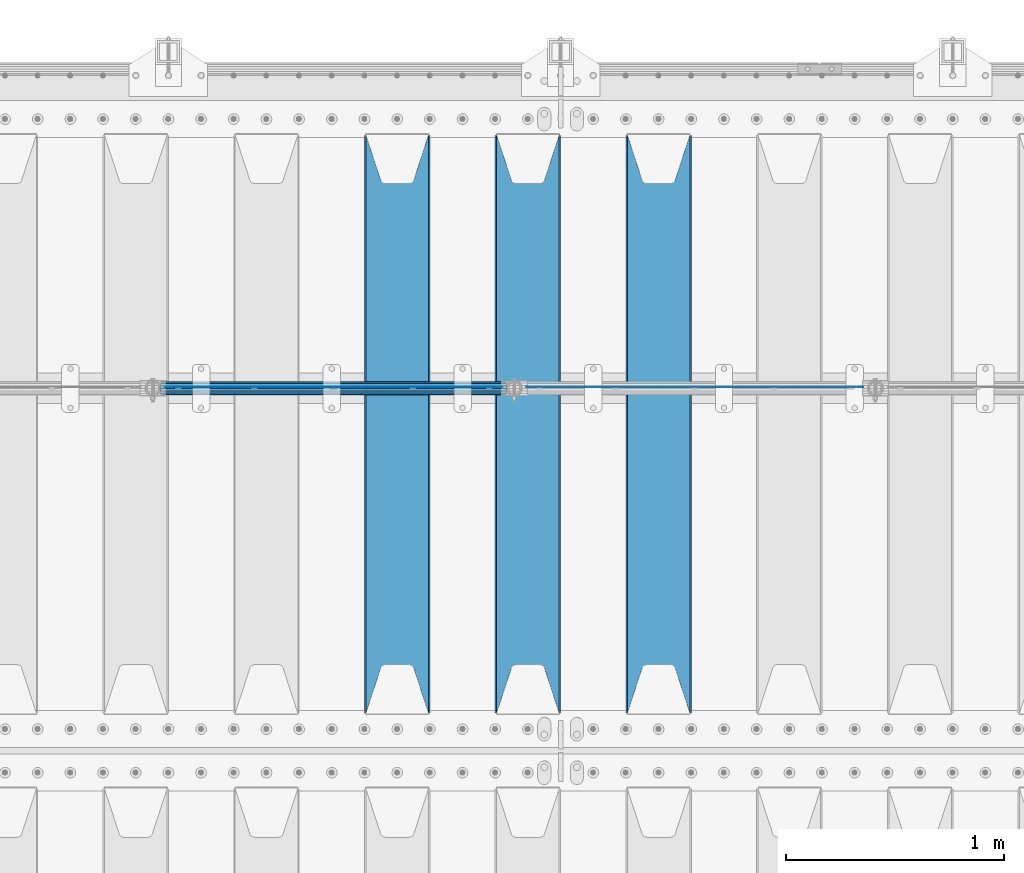
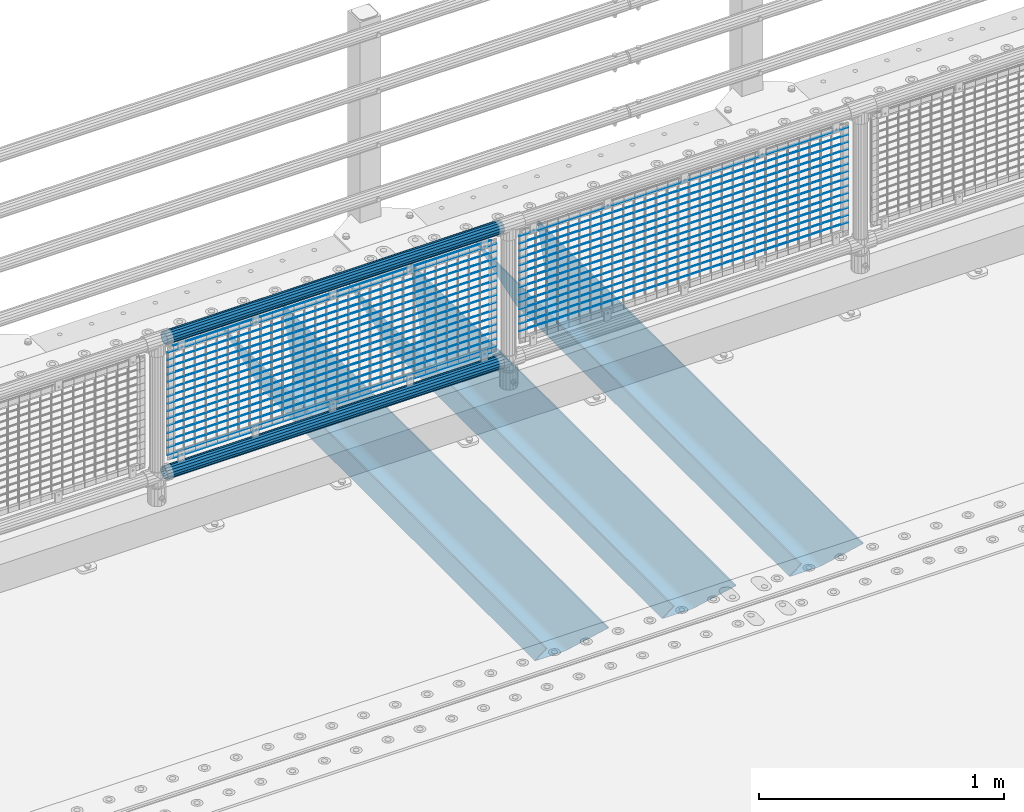
# One storey, part 116 of 240: 36 beams.
"""IFC2X3 building model written with IfcOpenShell, lengths in millimetres."""

from ifc_helpers import new_model, si_unit, frame, origin_with_axes, place, context, subcontext, project, spatial, faceted_brep, material, type_object, element, save


model = new_model("IFC2X3")

# Units and contexts
model_context = context("Model", 3, precision=1e-05, world=origin_with_axes())
body_context = subcontext(model_context, "Body", "Model", "MODEL_VIEW")
ifc_project = project(units=[si_unit("LENGTHUNIT", "METRE", prefix="MILLI"), si_unit("AREAUNIT", "SQUARE_METRE"), si_unit("VOLUMEUNIT", "CUBIC_METRE"), si_unit("MASSUNIT", "GRAM", prefix="KILO"), si_unit("TIMEUNIT", "SECOND"), si_unit("PLANEANGLEUNIT", "RADIAN"), si_unit("SOLIDANGLEUNIT", "STERADIAN"), si_unit("THERMODYNAMICTEMPERATUREUNIT", "DEGREE_CELSIUS"), si_unit("LUMINOUSINTENSITYUNIT", "LUMEN")], contexts=[model_context])

# Site, building, storey
site_placement = place(None, origin_with_axes())
site = spatial("IfcSite", under=ifc_project, at=site_placement, CompositionType="ELEMENT")
building_placement = place(site_placement, origin_with_axes())
building = spatial("IfcBuilding", under=site, at=building_placement, Name="Standard", CompositionType="ELEMENT")
storey_placement = place(building_placement, origin_with_axes())
storey = spatial("IfcBuildingStorey", under=building, at=storey_placement, Name="Undefined", CompositionType="ELEMENT", Elevation=0.0)

# Beams
ifc_material_1 = material(Name="STEEL/S355N")
beam_type_1 = type_object("IfcBeamType", PredefinedType="NOTDEFINED")
beam_1_placement = place(storey_placement, frame((47050.0, 33175.0, -115.0), z_axis=(0.0, 0.0, 1.0), x_axis=(0.0, 1.0, 0.0)))
element("IfcBeam", 1, at=beam_1_placement, inside=storey, type_object=beam_type_1, material=ifc_material_1, context=body_context, shape_type="Brep", body=[
    faceted_brep([(0.0, 150.0, 115.0), (0.0, 143.690000000002, 115.0), (2650.00000000297, 143.690000000002, 115.0), (2650.00000000297, 150.0, 115.0), (2650.00000000297, 142.059565218406, 110.000000003094), (2650.00000000297, 148.369565218403, 110.000000003094), (2441.90079219209, -80.1103600731149, -98.0992078077845), (2437.7588105432, -77.5672621345584, -102.241189456673), (2434.06523489747, -74.4080125315522, -105.934765102404), (2430.9108609509, -70.7102721255724, -109.089139048974), (2428.37322971128, -66.5649389910031, -111.626770288588), (2426.51472138055, -62.0739139532889, -113.485278619323), (2425.38102192092, -57.3475956567636, -114.618978078955), (2424.99999999987, -52.5021667386536, -115.0), (2424.99999999987, 52.5021667386536, -115.0), (2425.38102192092, 57.3475956567636, -114.618978078955), (2426.51472138055, 62.0739139532889, -113.485278619323), (2428.37322971128, 66.5649389910031, -111.626770288588), (2430.9108609509, 70.7102721255724, -109.089139048974), (2434.06523489747, 74.4080125315522, -105.934765102404), (2437.7588105432, 77.5672621345584, -102.241189456673), (2441.90079219209, 80.1103600731149, -98.0992078077846), (2446.38936140512, 81.9747917625791, -93.6106385947584), (2448.2494850041, 76.2713538057287, -91.7505149957729), (2444.62967112263, 74.76777986261, -95.3703288772456), (2441.28936334127, 72.7168944282894, -98.710636658607), (2438.31067330439, 70.1691124903809, -101.689326695487), (2435.76682334748, 67.1870637758839, -104.233176652398), (2433.72034654134, 63.8440531834931, -106.279653458539), (2432.22154950042, 60.2222587982324, -107.778450499454), (2431.30727574265, 56.4107117849126, -108.692724257221), (2430.99999999987, 52.5031078186876, -109.0), (2430.99999999987, -52.5031078186876, -109.0), (2431.30727574265, -56.4107117849126, -108.692724257221), (2432.22154950042, -60.2222587982324, -107.778450499454), (2433.72034654134, -63.8440531834931, -106.279653458539), (2435.76682334748, -67.1870637758839, -104.233176652398), (2438.31067330439, -70.1691124903809, -101.689326695487), (2441.28936334127, -72.7168944282894, -98.7106366586071), (2444.62967112263, -74.76777986261, -95.3703288772457), (2448.2494850041, -76.2713538057287, -91.7505149957729), (2650.00000000297, -142.059565218406, 110.000000003094), (2650.00000000297, -148.369565218403, 110.000000003094), (2446.38936140512, -81.9747917625791, -93.6106385947584), (2650.00000000297, -143.690000000002, 115.0), (2650.00000000297, -150.0, 115.0), (0.0, -143.690000000002, 115.0), (0.0, -150.0, 115.0), (0.0, -148.369565218258, 110.000000002667), (203.610638597427, -81.9747917625791, -93.6106385947584), (208.09920781045, -80.1103600731149, -98.0992078077845), (212.241189459342, -77.5672621345584, -102.241189456673), (215.93476510507, -74.4080125315522, -105.934765102404), (219.089139051641, -70.7102721255724, -109.089139048974), (221.626770291256, -66.5649389910031, -111.626770288588), (223.485278621989, -62.0739139532889, -113.485278619323), (224.618978081624, -57.3475956567636, -114.618978078955), (225.000000002663, -52.5021667386536, -115.0), (225.000000002663, 52.5021667386536, -115.0), (224.618978081624, 57.3475956567636, -114.618978078955), (223.485278621989, 62.0739139532889, -113.485278619323), (221.626770291256, 66.5649389910031, -111.626770288588), (219.089139051641, 70.7102721255724, -109.089139048974), (215.93476510507, 74.4080125315522, -105.934765102404), (212.241189459342, 77.5672621345584, -102.241189456673), (208.09920781045, 80.1103600731149, -98.0992078077846), (203.610638597427, 81.9747917625791, -93.6106385947584), (0.0, 148.369565218258, 110.000000002667), (0.0, 142.05956521826, 110.000000002667), (201.750514998439, 76.2713538057287, -91.7505149957729), (205.370328879908, 74.76777986261, -95.3703288772456), (208.710636661275, 72.7168944282894, -98.710636658607), (211.689326698153, 70.1691124903809, -101.689326695487), (214.233176655063, 67.1870637758839, -104.233176652398), (216.279653461206, 63.8440531834931, -106.279653458539), (217.778450502123, 60.2222587982324, -107.778450499454), (218.692724259887, 56.4107117849126, -108.692724257221), (219.000000002667, 52.5031078186876, -109.0), (219.000000002667, -52.5031078186876, -109.0), (218.692724259887, -56.4107117849126, -108.692724257221), (217.778450502123, -60.2222587982324, -107.778450499454), (216.279653461206, -63.8440531834931, -106.279653458539), (214.233176655063, -67.1870637758839, -104.233176652398), (211.689326698153, -70.1691124903809, -101.689326695487), (208.710636661275, -72.7168944282894, -98.7106366586071), (205.370328879915, -74.76777986261, -95.3703288772457), (201.750514998439, -76.2713538057287, -91.7505149957729), (0.0, -142.05956521826, 110.000000002667)], [[[0, 1, 2, 3]], [[3, 2, 4, 5]], [[6, 7, 8, 9, 10, 11, 12, 13, 14, 15, 16, 17, 18, 19, 20, 21, 22, 5, 4, 23, 24, 25, 26, 27, 28, 29, 30, 31, 32, 33, 34, 35, 36, 37, 38, 39, 40, 41, 42, 43]], [[44, 45, 42, 41]], [[46, 47, 45, 44]], [[43, 42, 45, 47, 48, 49]], [[6, 43, 49, 50]], [[7, 6, 50, 51]], [[8, 7, 51, 52]], [[9, 8, 52, 53]], [[10, 9, 53, 54]], [[11, 10, 54, 55]], [[12, 11, 55, 56]], [[13, 12, 56, 57]], [[14, 13, 57, 58]], [[15, 14, 58, 59]], [[16, 15, 59, 60]], [[17, 16, 60, 61]], [[18, 17, 61, 62]], [[19, 18, 62, 63]], [[20, 19, 63, 64]], [[21, 20, 64, 65]], [[22, 21, 65, 66]], [[0, 3, 5, 22, 66, 67]], [[1, 0, 67, 68]], [[23, 4, 2, 1, 68, 69]], [[24, 23, 69, 70]], [[25, 24, 70, 71]], [[26, 25, 71, 72]], [[27, 26, 72, 73]], [[28, 27, 73, 74]], [[29, 28, 74, 75]], [[30, 29, 75, 76]], [[31, 30, 76, 77]], [[32, 31, 77, 78]], [[33, 32, 78, 79]], [[34, 33, 79, 80]], [[35, 34, 80, 81]], [[36, 35, 81, 82]], [[37, 36, 82, 83]], [[38, 37, 83, 84]], [[39, 38, 84, 85]], [[40, 39, 85, 86]], [[46, 44, 41, 40, 86, 87]], [[47, 46, 87, 48]], [[86, 85, 84, 83, 82, 81, 80, 79, 78, 77, 76, 75, 74, 73, 72, 71, 70, 69, 68, 67, 66, 65, 64, 63, 62, 61, 60, 59, 58, 57, 56, 55, 54, 53, 52, 51, 50, 49, 48, 87]]]),
])
beam_2_placement = place(storey_placement, frame((46450.0, 33175.0, -115.0), z_axis=(0.0, 0.0, 1.0), x_axis=(0.0, 1.0, 0.0)))
element("IfcBeam", 2, at=beam_2_placement, inside=storey, type_object=beam_type_1, material=ifc_material_1, context=body_context, shape_type="Brep", body=[
    faceted_brep([(0.0, 150.0, 115.0), (0.0, 143.690000000002, 115.0), (2650.00000000297, 143.690000000002, 115.0), (2650.00000000297, 150.0, 115.0), (2650.00000000297, 142.059565218406, 110.000000003094), (2650.00000000297, 148.369565218403, 110.000000003094), (2441.90079219209, -80.1103600731149, -98.0992078077845), (2437.7588105432, -77.5672621345584, -102.241189456673), (2434.06523489747, -74.4080125315522, -105.934765102404), (2430.9108609509, -70.7102721255724, -109.089139048974), (2428.37322971128, -66.5649389910031, -111.626770288588), (2426.51472138055, -62.0739139532889, -113.485278619323), (2425.38102192092, -57.3475956567636, -114.618978078955), (2424.99999999987, -52.5021667386536, -115.0), (2424.99999999987, 52.5021667386536, -115.0), (2425.38102192092, 57.3475956567636, -114.618978078955), (2426.51472138055, 62.0739139532889, -113.485278619323), (2428.37322971128, 66.5649389910031, -111.626770288588), (2430.9108609509, 70.7102721255724, -109.089139048974), (2434.06523489747, 74.4080125315522, -105.934765102404), (2437.7588105432, 77.5672621345584, -102.241189456673), (2441.90079219209, 80.1103600731149, -98.0992078077846), (2446.38936140512, 81.9747917625791, -93.6106385947584), (2448.2494850041, 76.2713538057287, -91.7505149957729), (2444.62967112263, 74.76777986261, -95.3703288772456), (2441.28936334127, 72.7168944282894, -98.710636658607), (2438.31067330439, 70.1691124903809, -101.689326695487), (2435.76682334748, 67.1870637758839, -104.233176652398), (2433.72034654134, 63.8440531834931, -106.279653458539), (2432.22154950042, 60.2222587982324, -107.778450499454), (2431.30727574265, 56.4107117849126, -108.692724257221), (2430.99999999987, 52.5031078186876, -109.0), (2430.99999999987, -52.5031078186876, -109.0), (2431.30727574265, -56.4107117849126, -108.692724257221), (2432.22154950042, -60.2222587982324, -107.778450499454), (2433.72034654134, -63.8440531834931, -106.279653458539), (2435.76682334748, -67.1870637758839, -104.233176652398), (2438.31067330439, -70.1691124903809, -101.689326695487), (2441.28936334127, -72.7168944282894, -98.7106366586071), (2444.62967112263, -74.76777986261, -95.3703288772457), (2448.2494850041, -76.2713538057287, -91.7505149957729), (2650.00000000297, -142.059565218406, 110.000000003094), (2650.00000000297, -148.369565218403, 110.000000003094), (2446.38936140512, -81.9747917625791, -93.6106385947584), (2650.00000000297, -143.690000000002, 115.0), (2650.00000000297, -150.0, 115.0), (0.0, -143.690000000002, 115.0), (0.0, -150.0, 115.0), (0.0, -148.369565218258, 110.000000002667), (203.610638597427, -81.9747917625791, -93.6106385947584), (208.09920781045, -80.1103600731149, -98.0992078077845), (212.241189459342, -77.5672621345584, -102.241189456673), (215.93476510507, -74.4080125315522, -105.934765102404), (219.089139051641, -70.7102721255724, -109.089139048974), (221.626770291256, -66.5649389910031, -111.626770288588), (223.485278621989, -62.0739139532889, -113.485278619323), (224.618978081624, -57.3475956567636, -114.618978078955), (225.000000002663, -52.5021667386536, -115.0), (225.000000002663, 52.5021667386536, -115.0), (224.618978081624, 57.3475956567636, -114.618978078955), (223.485278621989, 62.0739139532889, -113.485278619323), (221.626770291256, 66.5649389910031, -111.626770288588), (219.089139051641, 70.7102721255724, -109.089139048974), (215.93476510507, 74.4080125315522, -105.934765102404), (212.241189459342, 77.5672621345584, -102.241189456673), (208.09920781045, 80.1103600731149, -98.0992078077846), (203.610638597427, 81.9747917625791, -93.6106385947584), (0.0, 148.369565218258, 110.000000002667), (0.0, 142.05956521826, 110.000000002667), (201.750514998439, 76.2713538057287, -91.7505149957729), (205.370328879908, 74.76777986261, -95.3703288772456), (208.710636661275, 72.7168944282894, -98.710636658607), (211.689326698153, 70.1691124903809, -101.689326695487), (214.233176655063, 67.1870637758839, -104.233176652398), (216.279653461206, 63.8440531834931, -106.279653458539), (217.778450502123, 60.2222587982324, -107.778450499454), (218.692724259887, 56.4107117849126, -108.692724257221), (219.000000002667, 52.5031078186876, -109.0), (219.000000002667, -52.5031078186876, -109.0), (218.692724259887, -56.4107117849126, -108.692724257221), (217.778450502123, -60.2222587982324, -107.778450499454), (216.279653461206, -63.8440531834931, -106.279653458539), (214.233176655063, -67.1870637758839, -104.233176652398), (211.689326698153, -70.1691124903809, -101.689326695487), (208.710636661275, -72.7168944282894, -98.7106366586071), (205.370328879915, -74.76777986261, -95.3703288772457), (201.750514998439, -76.2713538057287, -91.7505149957729), (0.0, -142.05956521826, 110.000000002667)], [[[0, 1, 2, 3]], [[3, 2, 4, 5]], [[6, 7, 8, 9, 10, 11, 12, 13, 14, 15, 16, 17, 18, 19, 20, 21, 22, 5, 4, 23, 24, 25, 26, 27, 28, 29, 30, 31, 32, 33, 34, 35, 36, 37, 38, 39, 40, 41, 42, 43]], [[44, 45, 42, 41]], [[46, 47, 45, 44]], [[43, 42, 45, 47, 48, 49]], [[6, 43, 49, 50]], [[7, 6, 50, 51]], [[8, 7, 51, 52]], [[9, 8, 52, 53]], [[10, 9, 53, 54]], [[11, 10, 54, 55]], [[12, 11, 55, 56]], [[13, 12, 56, 57]], [[14, 13, 57, 58]], [[15, 14, 58, 59]], [[16, 15, 59, 60]], [[17, 16, 60, 61]], [[18, 17, 61, 62]], [[19, 18, 62, 63]], [[20, 19, 63, 64]], [[21, 20, 64, 65]], [[22, 21, 65, 66]], [[0, 3, 5, 22, 66, 67]], [[1, 0, 67, 68]], [[23, 4, 2, 1, 68, 69]], [[24, 23, 69, 70]], [[25, 24, 70, 71]], [[26, 25, 71, 72]], [[27, 26, 72, 73]], [[28, 27, 73, 74]], [[29, 28, 74, 75]], [[30, 29, 75, 76]], [[31, 30, 76, 77]], [[32, 31, 77, 78]], [[33, 32, 78, 79]], [[34, 33, 79, 80]], [[35, 34, 80, 81]], [[36, 35, 81, 82]], [[37, 36, 82, 83]], [[38, 37, 83, 84]], [[39, 38, 84, 85]], [[40, 39, 85, 86]], [[46, 44, 41, 40, 86, 87]], [[47, 46, 87, 48]], [[86, 85, 84, 83, 82, 81, 80, 79, 78, 77, 76, 75, 74, 73, 72, 71, 70, 69, 68, 67, 66, 65, 64, 63, 62, 61, 60, 59, 58, 57, 56, 55, 54, 53, 52, 51, 50, 49, 48, 87]]]),
])
beam_3_placement = place(storey_placement, frame((45850.0, 33175.0, -115.0), z_axis=(0.0, 0.0, 1.0), x_axis=(0.0, 1.0, 0.0)))
element("IfcBeam", 3, at=beam_3_placement, inside=storey, type_object=beam_type_1, material=ifc_material_1, context=body_context, shape_type="Brep", body=[
    faceted_brep([(0.0, 150.0, 115.0), (0.0, 143.690000000002, 115.0), (2650.00000000297, 143.690000000002, 115.0), (2650.00000000297, 150.0, 115.0), (2650.00000000297, 142.059565218406, 110.000000003094), (2650.00000000297, 148.369565218403, 110.000000003094), (2441.90079219209, -80.1103600731149, -98.0992078077845), (2437.7588105432, -77.5672621345584, -102.241189456673), (2434.06523489747, -74.4080125315522, -105.934765102404), (2430.9108609509, -70.7102721255724, -109.089139048974), (2428.37322971128, -66.5649389910031, -111.626770288588), (2426.51472138055, -62.0739139532889, -113.485278619323), (2425.38102192092, -57.3475956567636, -114.618978078955), (2424.99999999987, -52.5021667386536, -115.0), (2424.99999999987, 52.5021667386536, -115.0), (2425.38102192092, 57.3475956567636, -114.618978078955), (2426.51472138055, 62.0739139532889, -113.485278619323), (2428.37322971128, 66.5649389910031, -111.626770288588), (2430.9108609509, 70.7102721255724, -109.089139048974), (2434.06523489747, 74.4080125315522, -105.934765102404), (2437.7588105432, 77.5672621345584, -102.241189456673), (2441.90079219209, 80.1103600731149, -98.0992078077846), (2446.38936140512, 81.9747917625791, -93.6106385947584), (2448.2494850041, 76.2713538057287, -91.7505149957729), (2444.62967112263, 74.76777986261, -95.3703288772456), (2441.28936334127, 72.7168944282894, -98.710636658607), (2438.31067330439, 70.1691124903809, -101.689326695487), (2435.76682334748, 67.1870637758839, -104.233176652398), (2433.72034654134, 63.8440531834931, -106.279653458539), (2432.22154950042, 60.2222587982324, -107.778450499454), (2431.30727574265, 56.4107117849126, -108.692724257221), (2430.99999999987, 52.5031078186876, -109.0), (2430.99999999987, -52.5031078186876, -109.0), (2431.30727574265, -56.4107117849126, -108.692724257221), (2432.22154950042, -60.2222587982324, -107.778450499454), (2433.72034654134, -63.8440531834931, -106.279653458539), (2435.76682334748, -67.1870637758839, -104.233176652398), (2438.31067330439, -70.1691124903809, -101.689326695487), (2441.28936334127, -72.7168944282894, -98.7106366586071), (2444.62967112263, -74.76777986261, -95.3703288772457), (2448.2494850041, -76.2713538057287, -91.7505149957729), (2650.00000000297, -142.059565218406, 110.000000003094), (2650.00000000297, -148.369565218403, 110.000000003094), (2446.38936140512, -81.9747917625791, -93.6106385947584), (2650.00000000297, -143.690000000002, 115.0), (2650.00000000297, -150.0, 115.0), (0.0, -143.690000000002, 115.0), (0.0, -150.0, 115.0), (0.0, -148.369565218258, 110.000000002667), (203.610638597427, -81.9747917625791, -93.6106385947584), (208.09920781045, -80.1103600731149, -98.0992078077845), (212.241189459342, -77.5672621345584, -102.241189456673), (215.93476510507, -74.4080125315522, -105.934765102404), (219.089139051641, -70.7102721255724, -109.089139048974), (221.626770291256, -66.5649389910031, -111.626770288588), (223.485278621989, -62.0739139532889, -113.485278619323), (224.618978081624, -57.3475956567636, -114.618978078955), (225.000000002663, -52.5021667386536, -115.0), (225.000000002663, 52.5021667386536, -115.0), (224.618978081624, 57.3475956567636, -114.618978078955), (223.485278621989, 62.0739139532889, -113.485278619323), (221.626770291256, 66.5649389910031, -111.626770288588), (219.089139051641, 70.7102721255724, -109.089139048974), (215.93476510507, 74.4080125315522, -105.934765102404), (212.241189459342, 77.5672621345584, -102.241189456673), (208.09920781045, 80.1103600731149, -98.0992078077846), (203.610638597427, 81.9747917625791, -93.6106385947584), (0.0, 148.369565218258, 110.000000002667), (0.0, 142.05956521826, 110.000000002667), (201.750514998439, 76.2713538057287, -91.7505149957729), (205.370328879908, 74.76777986261, -95.3703288772456), (208.710636661275, 72.7168944282894, -98.710636658607), (211.689326698153, 70.1691124903809, -101.689326695487), (214.233176655063, 67.1870637758839, -104.233176652398), (216.279653461206, 63.8440531834931, -106.279653458539), (217.778450502123, 60.2222587982324, -107.778450499454), (218.692724259887, 56.4107117849126, -108.692724257221), (219.000000002667, 52.5031078186876, -109.0), (219.000000002667, -52.5031078186876, -109.0), (218.692724259887, -56.4107117849126, -108.692724257221), (217.778450502123, -60.2222587982324, -107.778450499454), (216.279653461206, -63.8440531834931, -106.279653458539), (214.233176655063, -67.1870637758839, -104.233176652398), (211.689326698153, -70.1691124903809, -101.689326695487), (208.710636661275, -72.7168944282894, -98.7106366586071), (205.370328879915, -74.76777986261, -95.3703288772457), (201.750514998439, -76.2713538057287, -91.7505149957729), (0.0, -142.05956521826, 110.000000002667)], [[[0, 1, 2, 3]], [[3, 2, 4, 5]], [[6, 7, 8, 9, 10, 11, 12, 13, 14, 15, 16, 17, 18, 19, 20, 21, 22, 5, 4, 23, 24, 25, 26, 27, 28, 29, 30, 31, 32, 33, 34, 35, 36, 37, 38, 39, 40, 41, 42, 43]], [[44, 45, 42, 41]], [[46, 47, 45, 44]], [[43, 42, 45, 47, 48, 49]], [[6, 43, 49, 50]], [[7, 6, 50, 51]], [[8, 7, 51, 52]], [[9, 8, 52, 53]], [[10, 9, 53, 54]], [[11, 10, 54, 55]], [[12, 11, 55, 56]], [[13, 12, 56, 57]], [[14, 13, 57, 58]], [[15, 14, 58, 59]], [[16, 15, 59, 60]], [[17, 16, 60, 61]], [[18, 17, 61, 62]], [[19, 18, 62, 63]], [[20, 19, 63, 64]], [[21, 20, 64, 65]], [[22, 21, 65, 66]], [[0, 3, 5, 22, 66, 67]], [[1, 0, 67, 68]], [[23, 4, 2, 1, 68, 69]], [[24, 23, 69, 70]], [[25, 24, 70, 71]], [[26, 25, 71, 72]], [[27, 26, 72, 73]], [[28, 27, 73, 74]], [[29, 28, 74, 75]], [[30, 29, 75, 76]], [[31, 30, 76, 77]], [[32, 31, 77, 78]], [[33, 32, 78, 79]], [[34, 33, 79, 80]], [[35, 34, 80, 81]], [[36, 35, 81, 82]], [[37, 36, 82, 83]], [[38, 37, 83, 84]], [[39, 38, 84, 85]], [[40, 39, 85, 86]], [[46, 44, 41, 40, 86, 87]], [[47, 46, 87, 48]], [[86, 85, 84, 83, 82, 81, 80, 79, 78, 77, 76, 75, 74, 73, 72, 71, 70, 69, 68, 67, 66, 65, 64, 63, 62, 61, 60, 59, 58, 57, 56, 55, 54, 53, 52, 51, 50, 49, 48, 87]]]),
])
ifc_material_2 = material(Name="Misc_Undefined")
beam_type_2 = type_object("IfcBeamType", Name="D3", PredefinedType="NOTDEFINED")
for number, where, z_axis, x_axis in (
    (4, (46442.0, 34670.5, 851.597), (0.0, 0.0, 1.0), (1.0, 0.0, 0.0)),
    (5, (46442.0, 34670.5, 669.452), (0.0, 0.0, 1.0), (1.0, 0.0, 0.0)),
    (6, (46442.0, 34670.5, 523.736), (0.0, 0.0, 1.0), (1.0, 0.0, 0.0)),
    (7, (46442.0, 34670.5, 487.307), (0.0, 0.0, 1.0), (1.0, 0.0, 0.0)),
    (8, (46442.0, 34670.5, 705.881), (0.0, 0.0, 1.0), (1.0, 0.0, 0.0)),
    (9, (46442.0, 34670.5, 596.594), (0.0, 0.0, 1.0), (1.0, 0.0, 0.0)),
    (10, (46442.0, 34670.5, 450.878), (0.0, 0.0, 1.0), (1.0, 0.0, 0.0)),
    (11, (46442.0, 34670.5, 815.168), (0.0, 0.0, 1.0), (1.0, 0.0, 0.0)),
    (12, (46442.0, 34670.5, 888.026), (0.0, 0.0, 1.0), (1.0, 0.0, 0.0)),
    (13, (46442.0, 34670.5, 778.739), (0.0, 0.0, 1.0), (1.0, 0.0, 0.0)),
    (14, (46442.0, 34670.5, 742.31), (0.0, 0.0, 1.0), (1.0, 0.0, 0.0)),
    (15, (46442.0, 34670.5, 633.023), (0.0, 0.0, 1.0), (1.0, 0.0, 0.0)),
    (16, (46442.0, 34670.5, 560.165), (0.0, 0.0, 1.0), (1.0, 0.0, 0.0)),
    (17, (46442.0, 34670.5, 414.449), (0.0, 0.0, 1.0), (1.0, 0.0, 0.0)),
    (18, (44784.0, 34670.5, 851.597), (0.0, 0.0, 1.0), (1.0, 0.0, 0.0)),
    (19, (44784.0, 34670.5, 669.452), (0.0, 0.0, 1.0), (1.0, 0.0, 0.0)),
    (20, (44784.0, 34670.5, 523.736), (0.0, 0.0, 1.0), (1.0, 0.0, 0.0)),
    (21, (44784.0, 34670.5, 487.307), (0.0, 0.0, 1.0), (1.0, 0.0, 0.0)),
    (22, (44784.0, 34670.5, 705.881), (0.0, 0.0, 1.0), (1.0, 0.0, 0.0)),
    (23, (44784.0, 34670.5, 596.594), (0.0, 0.0, 1.0), (1.0, 0.0, 0.0)),
    (24, (44784.0, 34670.5, 450.878), (0.0, 0.0, 1.0), (1.0, 0.0, 0.0)),
    (25, (44784.0, 34670.5, 815.168), (0.0, 0.0, 1.0), (1.0, 0.0, 0.0)),
    (26, (44784.0, 34670.5, 888.026), (0.0, 0.0, 1.0), (1.0, 0.0, 0.0)),
    (27, (44784.0, 34670.5, 778.739), (0.0, 0.0, 1.0), (1.0, 0.0, 0.0)),
    (28, (44784.0, 34670.5, 742.31), (0.0, 0.0, 1.0), (1.0, 0.0, 0.0)),
    (29, (44784.0, 34670.5, 633.023), (0.0, 0.0, 1.0), (1.0, 0.0, 0.0)),
    (30, (44784.0, 34670.5, 560.165), (0.0, 0.0, 1.0), (1.0, 0.0, 0.0)),
    (31, (44784.0, 34670.5, 414.449), (0.0, 0.0, 1.0), (1.0, 0.0, 0.0)),
):
    element("IfcBeam", number, at=place(storey_placement, frame(where, z_axis=z_axis, x_axis=x_axis)), inside=storey, type_object=beam_type_2, material=ifc_material_2, ObjectType="D3", context=body_context, shape_type="Brep", body=[
        faceted_brep([(-7.27595761418343e-12, -1.49999999999272, 0.0), (-7.27595761418343e-12, -0.749999999992724, -1.29903810567669), (1548.0, -0.75, -1.29903810567669), (1548.0, -1.5, 0.0), (0.0, 0.750000000007276, -1.29903810567669), (1548.0, 0.75, -1.29903810567669), (0.0, 1.50000000000728, 0.0), (1548.0, 1.5, 0.0), (0.0, 0.750000000007276, 1.29903810567669), (1548.0, 0.75, 1.29903810567669), (-7.27595761418343e-12, -0.749999999992724, 1.29903810567669), (1548.0, -0.75, 1.29903810567669)], [[[0, 1, 2, 3]], [[1, 4, 5, 2]], [[4, 6, 7, 5]], [[6, 8, 9, 7]], [[8, 10, 11, 9]], [[10, 0, 3, 11]], [[5, 7, 9, 11, 3, 2]], [[10, 8, 6, 4, 1, 0]]]),
    ])
beam_4_placement = place(storey_placement, frame((44809.0, 34670.5, 353.02), z_axis=(0.0, 0.0, 1.0), x_axis=(1.0, 0.0, 0.0)))
element("IfcBeam", 32, at=beam_4_placement, inside=storey, type_object=beam_type_2, material=ifc_material_2, ObjectType="D3", context=body_context, shape_type="Brep", body=[
    faceted_brep([(-7.27595761418343e-12, -1.49999999999272, 0.0), (-7.27595761418343e-12, -0.749999999992724, -1.29903810567669), (1498.0, -0.75, -1.29903810567669), (1498.0, -1.5, 0.0), (0.0, 0.750000000007276, -1.29903810567669), (1498.0, 0.75, -1.29903810567663), (0.0, 1.50000000000728, 0.0), (1498.0, 1.5, 0.0), (0.0, 0.750000000007276, 1.29903810567669), (1498.0, 0.75, 1.29903810567669), (-7.27595761418343e-12, -0.749999999992724, 1.29903810567669), (1498.0, -0.75, 1.29903810567669)], [[[0, 1, 2, 3]], [[1, 4, 5, 2]], [[4, 6, 7, 5]], [[6, 8, 9, 7]], [[8, 10, 11, 9]], [[10, 0, 3, 11]], [[5, 7, 9, 11, 3, 2]], [[10, 8, 6, 4, 1, 0]]]),
])
beam_5_placement = place(storey_placement, frame((44784.0, 34670.5, 378.02), z_axis=(0.0, 0.0, 1.0), x_axis=(1.0, 0.0, 0.0)))
element("IfcBeam", 33, at=beam_5_placement, inside=storey, type_object=beam_type_2, material=ifc_material_2, ObjectType="D3", context=body_context, shape_type="Brep", body=[
    faceted_brep([(-7.27595761418343e-12, -1.49999999999272, 0.0), (-7.27595761418343e-12, -0.749999999992724, -1.29903810567669), (1548.0, -0.75, -1.29903810567669), (1548.0, -1.5, 0.0), (0.0, 0.750000000007276, -1.29903810567669), (1548.0, 0.75, -1.29903810567669), (0.0, 1.50000000000728, 0.0), (1548.0, 1.5, 0.0), (0.0, 0.750000000007276, 1.29903810567669), (1548.0, 0.75, 1.29903810567669), (-7.27595761418343e-12, -0.749999999992724, 1.29903810567669), (1548.0, -0.75, 1.29903810567669)], [[[0, 1, 2, 3]], [[1, 4, 5, 2]], [[4, 6, 7, 5]], [[6, 8, 9, 7]], [[8, 10, 11, 9]], [[10, 0, 3, 11]], [[5, 7, 9, 11, 3, 2]], [[10, 8, 6, 4, 1, 0]]]),
])
beam_6_placement = place(storey_placement, frame((44809.0, 34670.5, 913.02), z_axis=(0.0, 0.0, 1.0), x_axis=(1.0, 0.0, 0.0)))
element("IfcBeam", 34, at=beam_6_placement, inside=storey, type_object=beam_type_2, material=ifc_material_2, ObjectType="D3", context=body_context, shape_type="Brep", body=[
    faceted_brep([(-7.27595761418343e-12, -1.49999999999272, 0.0), (-7.27595761418343e-12, -0.749999999992724, -1.29903810567669), (1498.0, -0.75, -1.29903810567669), (1498.0, -1.5, 0.0), (0.0, 0.750000000007276, -1.29903810567669), (1498.0, 0.75, -1.29903810567663), (0.0, 1.50000000000728, 0.0), (1498.0, 1.5, 0.0), (0.0, 0.750000000007276, 1.29903810567669), (1498.0, 0.75, 1.29903810567669), (-7.27595761418343e-12, -0.749999999992724, 1.29903810567669), (1498.0, -0.75, 1.29903810567669)], [[[0, 1, 2, 3]], [[1, 4, 5, 2]], [[4, 6, 7, 5]], [[6, 8, 9, 7]], [[8, 10, 11, 9]], [[10, 0, 3, 11]], [[5, 7, 9, 11, 3, 2]], [[10, 8, 6, 4, 1, 0]]]),
])
ifc_material_3 = material()
beam_type_3 = type_object("IfcBeamType", PredefinedType="NOTDEFINED")
beam_7_placement = place(storey_placement, frame((44763.85, 34664.5, 969.85), z_axis=(0.0, 0.0, 1.0), x_axis=(1.0, 0.0, 0.0)))
element("IfcBeam", 35, at=beam_7_placement, inside=storey, type_object=beam_type_3, material=ifc_material_3, context=body_context, shape_type="Brep", body=[
    faceted_brep([(0.0, -25.3499999999985, 0.0), (0.0, -23.4203461491634, 9.70102501045767), (1588.0, -23.4203461491634, 9.70102501045506), (1588.0, -25.3499999999985, 0.0), (0.0, -17.9251569030821, 17.9251569030821), (1588.0, -17.9251569030821, 17.925156903079), (0.0, -9.70102501045767, 23.4203461491634), (1588.0, -9.70102501045767, 23.4203461491611), (0.0, 0.0, 25.3499999999985), (1588.0, 0.0, 25.35), (0.0, 9.70102501045767, 23.4203461491634), (1588.0, 9.70102501045767, 23.4203461491611), (0.0, 17.9251569030821, 17.9251569030821), (1588.0, 17.9251569030821, 17.925156903079), (0.0, 23.4203461491634, 9.70102501045767), (1588.0, 23.4203461491634, 9.70102501045506), (0.0, 25.3499999999985, 0.0), (1588.0, 25.3499999999985, 0.0), (0.0, 23.4203461491634, -9.70102501045767), (1588.0, 23.4203461491634, -9.70102501045506), (0.0, 17.9251569030821, -17.9251569030821), (1588.0, 17.9251569030821, -17.925156903079), (0.0, 9.70102501045767, -23.4203461491634), (1588.0, 9.70102501045767, -23.4203461491611), (0.0, 0.0, -25.3499999999985), (1588.0, 0.0, -25.35), (0.0, -9.70102501045767, -23.4203461491634), (1588.0, -9.70102501045767, -23.4203461491611), (0.0, -17.9251569030821, -17.9251569030821), (1588.0, -17.9251569030821, -17.925156903079), (0.0, -23.4203461491634, -9.70102501045767), (1588.0, -23.4203461491634, -9.70102501045506), (0.0, -30.1500000000015, 0.0), (0.0, -27.8549679052157, -11.5379054858058), (1588.0, -27.8549679052157, -11.5379054858075), (1588.0, -30.1500000000015, 0.0), (0.0, -21.3192694527752, -21.3192694527752), (1588.0, -21.3192694527752, -21.3192694527744), (0.0, -11.5379054858058, -27.8549679052157), (1588.0, -11.5379054858058, -27.8549679052153), (0.0, 0.0, -30.1500000000015), (1588.0, 0.0, -30.15), (0.0, 11.5379054858058, -27.8549679052157), (1588.0, 11.5379054858058, -27.8549679052153), (0.0, 21.3192694527752, -21.3192694527752), (1588.0, 21.3192694527752, -21.3192694527744), (0.0, 27.8549679052157, -11.5379054858058), (1588.0, 27.8549679052157, -11.5379054858074), (0.0, 30.1500000000015, 0.0), (1588.0, 30.1500000000015, 0.0), (0.0, 27.8549679052157, 11.5379054858058), (1588.0, 27.8549679052157, 11.5379054858074), (0.0, 21.3192694527752, 21.3192694527752), (1588.0, 21.3192694527752, 21.3192694527744), (0.0, 11.5379054858058, 27.8549679052157), (1588.0, 11.5379054858058, 27.8549679052153), (0.0, 0.0, 30.1500000000015), (1588.0, 0.0, 30.15), (0.0, -11.5379054858058, 27.8549679052157), (1588.0, -11.5379054858058, 27.8549679052153), (0.0, -21.3192694527752, 21.3192694527752), (1588.0, -21.3192694527752, 21.3192694527744), (0.0, -27.8549679052157, 11.5379054858058), (1588.0, -27.8549679052157, 11.5379054858074)], [[[0, 1, 2, 3]], [[1, 4, 5, 2]], [[4, 6, 7, 5]], [[6, 8, 9, 7]], [[8, 10, 11, 9]], [[10, 12, 13, 11]], [[12, 14, 15, 13]], [[14, 16, 17, 15]], [[16, 18, 19, 17]], [[18, 20, 21, 19]], [[20, 22, 23, 21]], [[22, 24, 25, 23]], [[24, 26, 27, 25]], [[26, 28, 29, 27]], [[28, 30, 31, 29]], [[30, 0, 3, 31]], [[32, 33, 34, 35]], [[33, 36, 37, 34]], [[36, 38, 39, 37]], [[38, 40, 41, 39]], [[40, 42, 43, 41]], [[42, 44, 45, 43]], [[44, 46, 47, 45]], [[46, 48, 49, 47]], [[48, 50, 51, 49]], [[50, 52, 53, 51]], [[52, 54, 55, 53]], [[54, 56, 57, 55]], [[56, 58, 59, 57]], [[58, 60, 61, 59]], [[60, 62, 63, 61]], [[62, 32, 35, 63]], [[37, 39, 41, 43, 45, 47, 49, 51, 53, 55, 57, 59, 61, 63, 35, 34], [5, 7, 9, 11, 13, 15, 17, 19, 21, 23, 25, 27, 29, 31, 3, 2]], [[62, 60, 58, 56, 54, 52, 50, 48, 46, 44, 42, 40, 38, 36, 33, 32], [30, 28, 26, 24, 22, 20, 18, 16, 14, 12, 10, 8, 6, 4, 1, 0]]]),
])
beam_8_placement = place(storey_placement, frame((44763.85, 34664.5, 298.170000000001), z_axis=(0.0, 0.0, 1.0), x_axis=(1.0, 0.0, 0.0)))
element("IfcBeam", 36, at=beam_8_placement, inside=storey, type_object=beam_type_3, material=ifc_material_3, context=body_context, shape_type="Brep", body=[
    faceted_brep([(0.0, -25.3499999999985, 0.0), (0.0, -23.4203461491634, 9.70102501045767), (1588.0, -23.4203461491634, 9.70102501045506), (1588.0, -25.3499999999985, 0.0), (0.0, -17.9251569030821, 17.9251569030821), (1588.0, -17.9251569030821, 17.925156903079), (0.0, -9.70102501045767, 23.4203461491634), (1588.0, -9.70102501045767, 23.4203461491611), (0.0, 0.0, 25.3499999999985), (1588.0, 0.0, 25.35), (0.0, 9.70102501045767, 23.4203461491634), (1588.0, 9.70102501045767, 23.4203461491611), (0.0, 17.9251569030821, 17.9251569030821), (1588.0, 17.9251569030821, 17.925156903079), (0.0, 23.4203461491634, 9.70102501045767), (1588.0, 23.4203461491634, 9.70102501045506), (0.0, 25.3499999999985, 0.0), (1588.0, 25.3499999999985, 0.0), (0.0, 23.4203461491634, -9.70102501045767), (1588.0, 23.4203461491634, -9.70102501045506), (0.0, 17.9251569030821, -17.9251569030821), (1588.0, 17.9251569030821, -17.925156903079), (0.0, 9.70102501045767, -23.4203461491634), (1588.0, 9.70102501045767, -23.4203461491611), (0.0, 0.0, -25.3499999999985), (1588.0, 0.0, -25.35), (0.0, -9.70102501045767, -23.4203461491634), (1588.0, -9.70102501045767, -23.4203461491611), (0.0, -17.9251569030821, -17.9251569030821), (1588.0, -17.9251569030821, -17.925156903079), (0.0, -23.4203461491634, -9.70102501045767), (1588.0, -23.4203461491634, -9.70102501045506), (0.0, -30.1500000000015, 0.0), (0.0, -27.8549679052157, -11.5379054858058), (1588.0, -27.8549679052157, -11.5379054858075), (1588.0, -30.1500000000015, 0.0), (0.0, -21.3192694527752, -21.3192694527752), (1588.0, -21.3192694527752, -21.3192694527744), (0.0, -11.5379054858058, -27.8549679052157), (1588.0, -11.5379054858058, -27.8549679052153), (0.0, 0.0, -30.1500000000015), (1588.0, 0.0, -30.15), (0.0, 11.5379054858058, -27.8549679052157), (1588.0, 11.5379054858058, -27.8549679052153), (0.0, 21.3192694527752, -21.3192694527752), (1588.0, 21.3192694527752, -21.3192694527744), (0.0, 27.8549679052157, -11.5379054858058), (1588.0, 27.8549679052157, -11.5379054858074), (0.0, 30.1500000000015, 0.0), (1588.0, 30.1500000000015, 0.0), (0.0, 27.8549679052157, 11.5379054858058), (1588.0, 27.8549679052157, 11.5379054858074), (0.0, 21.3192694527752, 21.3192694527752), (1588.0, 21.3192694527752, 21.3192694527744), (0.0, 11.5379054858058, 27.8549679052157), (1588.0, 11.5379054858058, 27.8549679052153), (0.0, 0.0, 30.1500000000015), (1588.0, 0.0, 30.15), (0.0, -11.5379054858058, 27.8549679052157), (1588.0, -11.5379054858058, 27.8549679052153), (0.0, -21.3192694527752, 21.3192694527752), (1588.0, -21.3192694527752, 21.3192694527744), (0.0, -27.8549679052157, 11.5379054858058), (1588.0, -27.8549679052157, 11.5379054858074)], [[[0, 1, 2, 3]], [[1, 4, 5, 2]], [[4, 6, 7, 5]], [[6, 8, 9, 7]], [[8, 10, 11, 9]], [[10, 12, 13, 11]], [[12, 14, 15, 13]], [[14, 16, 17, 15]], [[16, 18, 19, 17]], [[18, 20, 21, 19]], [[20, 22, 23, 21]], [[22, 24, 25, 23]], [[24, 26, 27, 25]], [[26, 28, 29, 27]], [[28, 30, 31, 29]], [[30, 0, 3, 31]], [[32, 33, 34, 35]], [[33, 36, 37, 34]], [[36, 38, 39, 37]], [[38, 40, 41, 39]], [[40, 42, 43, 41]], [[42, 44, 45, 43]], [[44, 46, 47, 45]], [[46, 48, 49, 47]], [[48, 50, 51, 49]], [[50, 52, 53, 51]], [[52, 54, 55, 53]], [[54, 56, 57, 55]], [[56, 58, 59, 57]], [[58, 60, 61, 59]], [[60, 62, 63, 61]], [[62, 32, 35, 63]], [[37, 39, 41, 43, 45, 47, 49, 51, 53, 55, 57, 59, 61, 63, 35, 34], [5, 7, 9, 11, 13, 15, 17, 19, 21, 23, 25, 27, 29, 31, 3, 2]], [[62, 60, 58, 56, 54, 52, 50, 48, 46, 44, 42, 40, 38, 36, 33, 32], [30, 28, 26, 24, 22, 20, 18, 16, 14, 12, 10, 8, 6, 4, 1, 0]]]),
])

save(model, "model.ifc")
